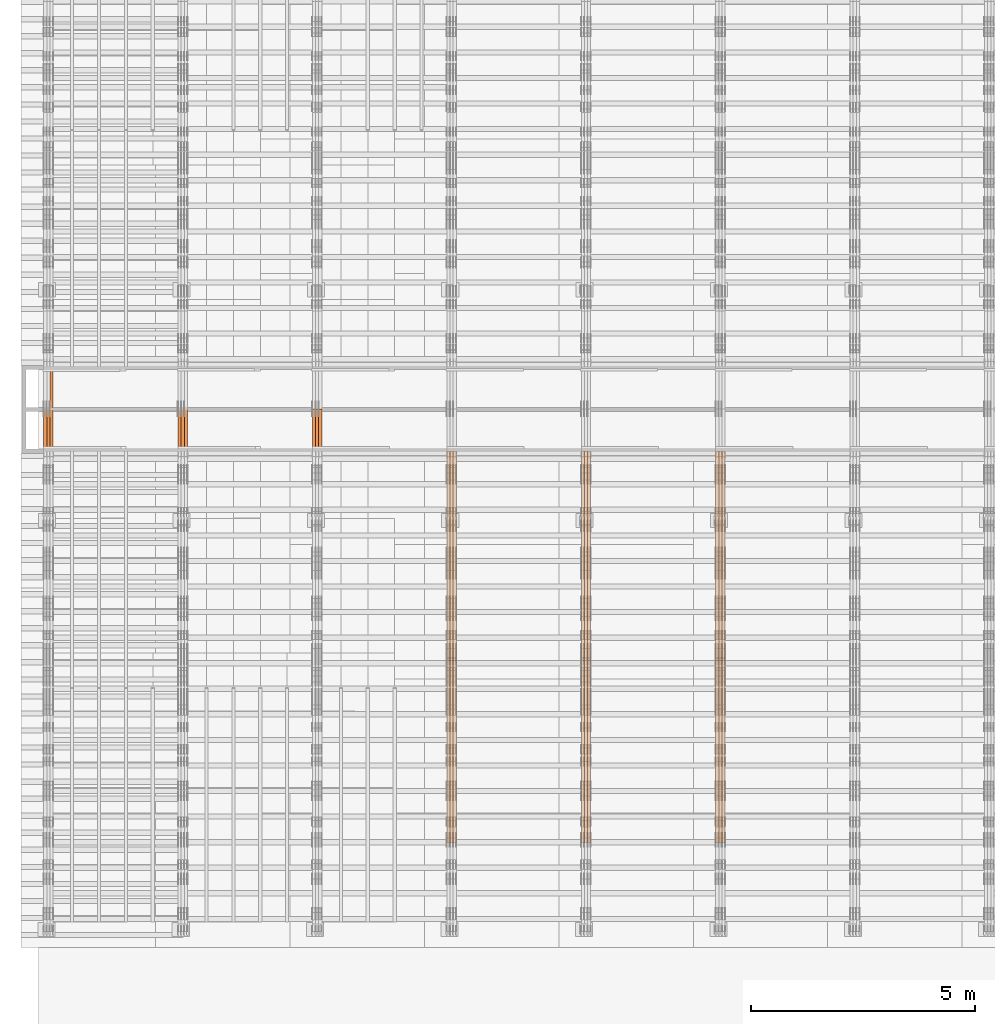
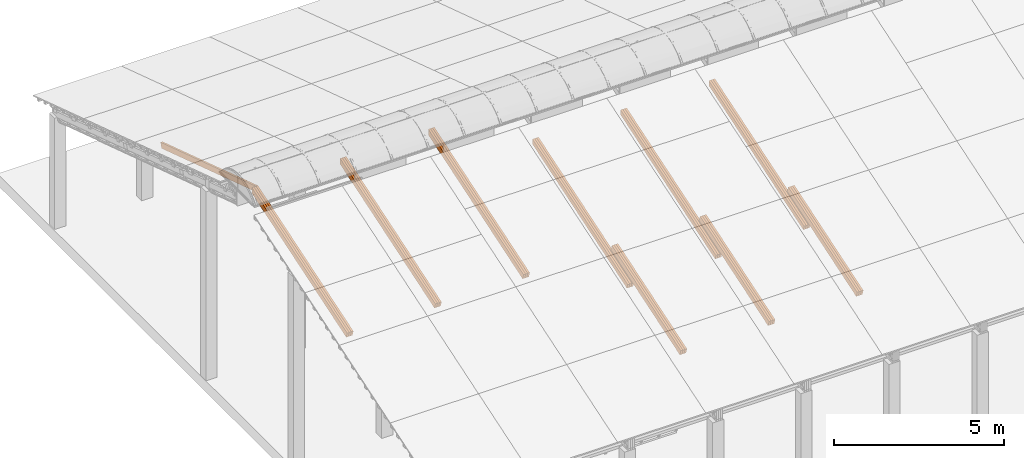
# One storey, part 13 of 385: 28 proxies.
"""IFC2X3 building model written with IfcOpenShell, lengths in millimetres."""

import ifcopenshell
import ifcopenshell.guid

model = None  # the IFC model being written
_history = None  # IfcOwnerHistory: only IFC2X3 demands one
_inside = {}  # id of a spatial element -> (the spatial element, [elements in it])
_under = {}  # id of a project, library or spatial element -> (it, [spatial elements below it])
_declared = {}  # id of a project -> (the project, [libraries it declares])
_typed = {}  # id of a type object -> (the type object, [elements of that type])
_made_of = {}  # id of a material, layer set ... -> (it, [elements and type objects made of it])


def new_model(schema):
    """Start an empty IFC model of exactly this schema.

    Asked for "IFC4X3", IfcOpenShell would pick the latest addendum, in which some entities
    have other attributes; the version numbers below select the first issue.
    IFC2X3 requires an IfcOwnerHistory on every rooted entity: one is made here for all.
    """
    global model, _history
    if schema == "IFC4X3":
        model = ifcopenshell.file(schema_version=(4, 3, 0, 0))
    else:
        model = ifcopenshell.file(schema=schema)
    _inside.clear()
    _under.clear()
    _declared.clear()
    _typed.clear()
    _made_of.clear()
    _history = None
    if model.schema == "IFC2X3":
        org = make("IfcOrganization", Name="unknown")
        user = make(
            "IfcPersonAndOrganization",
            ThePerson=make("IfcPerson", FamilyName="unknown"),
            TheOrganization=org,
        )
        app = make(
            "IfcApplication",
            ApplicationDeveloper=org,
            Version="unknown",
            ApplicationFullName="unknown",
            ApplicationIdentifier="unknown",
        )
        _history = make(
            "IfcOwnerHistory",
            OwningUser=user,
            OwningApplication=app,
            ChangeAction="ADDED",
            CreationDate=0,
        )
    return model


def make(cls, **values):
    """One entity of the class cls with the attributes given. An attribute that is None is left unset."""
    return model.create_entity(
        cls, **{name: value for name, value in values.items() if value is not None}
    )


def entity(cls, *values):
    """Any entity or typed value of the class cls, its attributes in the order of the schema. None: left unset."""
    e = model.create_entity(cls)
    for i, value in enumerate(values):
        if value is not None:
            e[i] = value
    return e


def rooted(cls, **values):
    """An entity with a GlobalId (a new one), such as an element, a storey or a relation."""
    return make(cls, GlobalId=ifcopenshell.guid.new(), OwnerHistory=_history, **values)


def si_unit(unit_type, name, prefix=None):
    """IfcSIUnit, for example si_unit("LENGTHUNIT", "METRE", prefix="MILLI")."""
    return make("IfcSIUnit", UnitType=unit_type, Prefix=prefix, Name=name)


def converted_unit(unit_type, name, factor, base, dimensions=None, offset=None):
    """IfcConversionBasedUnit, such as the inch: factor (a typed value) times the base unit."""
    return make(
        "IfcConversionBasedUnit"
        if offset is None
        else "IfcConversionBasedUnitWithOffset",
        ConversionOffset=offset,
        Dimensions=None
        if dimensions is None
        else entity("IfcDimensionalExponents", *dimensions),
        UnitType=unit_type,
        Name=name,
        ConversionFactor=make(
            "IfcMeasureWithUnit", ValueComponent=factor, UnitComponent=base
        ),
    )


def derived_unit(unit_type, elements):
    """IfcDerivedUnit: a product of units, each with its exponent."""
    return make(
        "IfcDerivedUnit",
        Elements=[
            make("IfcDerivedUnitElement", Unit=unit, Exponent=power)
            for unit, power in elements
        ],
        UnitType=unit_type,
    )


def assignment(units):
    """IfcUnitAssignment: the units of a project."""
    return None if units is None else make("IfcUnitAssignment", Units=units)


def point(xyz):
    """IfcCartesianPoint."""
    return None if xyz is None else make("IfcCartesianPoint", Coordinates=xyz)


def direction(xyz):
    """IfcDirection."""
    return None if xyz is None else make("IfcDirection", DirectionRatios=xyz)


def frame(location, z_axis=None, x_axis=None):
    """IfcAxis2Placement3D, a coordinate frame: its origin and axes. An axis left out is left unset."""
    return make(
        "IfcAxis2Placement3D",
        Location=point(location),
        Axis=direction(z_axis),
        RefDirection=direction(x_axis),
    )


def origin():
    """The frame at (0, 0, 0) with its axes left unset."""
    return frame((0.0, 0.0, 0.0))


def place(relative_to, where):
    """IfcLocalPlacement: puts the frame where relative to a parent placement (None: the world)."""
    return make(
        "IfcLocalPlacement", PlacementRelTo=relative_to, RelativePlacement=where
    )


def context(
    kind, dimensions, precision=None, world=None, true_north=None, identifier=None
):
    """IfcGeometricRepresentationContext, for example the 3D "Model" context."""
    return make(
        "IfcGeometricRepresentationContext",
        ContextIdentifier=identifier,
        ContextType=kind,
        CoordinateSpaceDimension=dimensions,
        Precision=precision,
        WorldCoordinateSystem=world,
        TrueNorth=true_north,
    )


def subcontext(parent, identifier, kind, view, scale=None):
    """IfcGeometricRepresentationSubContext, for example "Body" below "Model"."""
    return make(
        "IfcGeometricRepresentationSubContext",
        ContextIdentifier=identifier,
        ContextType=kind,
        ParentContext=parent,
        TargetScale=scale,
        TargetView=view,
    )


def project(units=None, contexts=None):
    """IfcProject with its units and contexts."""
    return rooted(
        "IfcProject",
        Name="project",
        RepresentationContexts=contexts,
        UnitsInContext=assignment(units),
    )


def spatial(cls, under=None, at=None, **own):
    """A site, building, storey or space (cls), placed at a placement, below another one or the project."""
    s = rooted(cls, ObjectPlacement=at, **own)
    if under is not None:
        _under.setdefault(under.id(), (under, []))[1].append(s)
    return s


def polyline(points):
    """IfcPolyline through the points."""
    return make("IfcPolyline", Points=[point(p) for p in points])


def outline(outer, holes=None, kind="AREA"):
    """IfcArbitraryClosedProfileDef: a profile drawn as a closed curve; with holes, ...WithVoids."""
    if holes is None:
        return make("IfcArbitraryClosedProfileDef", ProfileType=kind, OuterCurve=outer)
    return make(
        "IfcArbitraryProfileDefWithVoids",
        ProfileType=kind,
        OuterCurve=outer,
        InnerCurves=holes,
    )


def extrude(swept, where, along, depth):
    """IfcExtrudedAreaSolid: the profile swept, set in the frame where, extruded along a direction by depth."""
    return make(
        "IfcExtrudedAreaSolid",
        SweptArea=swept,
        Position=where,
        ExtrudedDirection=direction(along),
        Depth=depth,
    )


def shape(context_of_items, identifier, shape_type, items):
    """IfcShapeRepresentation: the items that make up one representation, for example the "Body"."""
    return make(
        "IfcShapeRepresentation",
        ContextOfItems=context_of_items,
        RepresentationIdentifier=identifier,
        RepresentationType=shape_type,
        Items=items,
    )


def source(mapping_origin, context_of_items, identifier, shape_type, items):
    """IfcRepresentationMap: a shape defined once, which mapped items show again and again."""
    return make(
        "IfcRepresentationMap",
        MappingOrigin=mapping_origin,
        MappedRepresentation=shape(context_of_items, identifier, shape_type, items),
    )


def transform(
    local_origin,
    x_axis=None,
    y_axis=None,
    z_axis=None,
    scale=None,
    scale2=None,
    scale3=None,
    uniform=True,
):
    """IfcCartesianTransformationOperator3D, or its non-uniform kind. x_axis, y_axis, z_axis: its Axis1, 2, 3."""
    if uniform:
        return make(
            "IfcCartesianTransformationOperator3D",
            Axis1=direction(x_axis),
            Axis2=direction(y_axis),
            LocalOrigin=point(local_origin),
            Scale=scale,
            Axis3=direction(z_axis),
        )
    return make(
        "IfcCartesianTransformationOperator3DnonUniform",
        Axis1=direction(x_axis),
        Axis2=direction(y_axis),
        LocalOrigin=point(local_origin),
        Scale=scale,
        Axis3=direction(z_axis),
        Scale2=scale2,
        Scale3=scale3,
    )


def mapped(mapping_source, mapping_target):
    """IfcMappedItem: shows the shape of a source again, moved by a transform."""
    return make(
        "IfcMappedItem", MappingSource=mapping_source, MappingTarget=mapping_target
    )


def material(Name=None, Category=None):
    """IfcMaterial."""
    return make("IfcMaterial", Name=Name, Category=Category)


def made_of(thing, what):
    """Note that an element or type object is made of a material, layer set ...; save() writes the relation."""
    if what is not None:
        _made_of.setdefault(what.id(), (what, []))[1].append(thing)
    return thing


def type_object(cls, material=None, **own):
    """A type object (cls), such as IfcWallType, which elements share."""
    return made_of(rooted(cls, **own), material)


def type_shapes(of_type, sources):
    """Give a type object the sources (RepresentationMaps) that its elements show as mapped items."""
    of_type.RepresentationMaps = sources


def element(
    cls,
    number,
    at=None,
    inside=None,
    cuts=None,
    type_object=None,
    material=None,
    context=None,
    identifier="Body",
    shape_type=None,
    held_by="IfcProductDefinitionShape",
    body=None,
    shapes=None,
    **own,
):
    """One element of the class cls, such as IfcWall. Its Tag is "e" and its number.

    at: its placement. inside: the storey or other place that contains it. cuts: it is an
    opening in that element (IfcRelVoidsElement). A single representation is given by context,
    identifier, shape_type and body (its items); several are given by shapes. held_by: the class
    of the entity that holds the representations. save() writes the other relations.
    """
    e = rooted(cls, Tag="e%d" % number, ObjectPlacement=at, **own)
    if body is not None:
        shapes = [shape(context, identifier, shape_type, body)]
    if shapes is not None:
        e.Representation = make(held_by, Representations=shapes)
    if inside is not None:
        _inside.setdefault(inside.id(), (inside, []))[1].append(e)
    if cuts is not None:
        rooted(
            "IfcRelVoidsElement", RelatingBuildingElement=cuts, RelatedOpeningElement=e
        )
    if type_object is not None:
        _typed.setdefault(type_object.id(), (type_object, []))[1].append(e)
    return made_of(e, material)


def aggregate(whole, parts):
    """IfcRelAggregates: a whole, such as a stair, and the parts it consists of."""
    return rooted("IfcRelAggregates", RelatingObject=whole, RelatedObjects=parts)


def save(model, path):
    """Write the relations noted so far, then the file.

    IfcRelAggregates (storeys below a building ...), IfcRelContainedInSpatialStructure (elements
    in a storey), IfcRelDefinesByType, IfcRelAssociatesMaterial and IfcRelDeclares: one each for
    every whole, place, type object, material and project.
    """
    for whole, parts in _under.values():
        aggregate(whole, parts)
    for where, things in _inside.values():
        rooted(
            "IfcRelContainedInSpatialStructure",
            RelatedElements=things,
            RelatingStructure=where,
        )
    for kind, things in _typed.values():
        rooted("IfcRelDefinesByType", RelatedObjects=things, RelatingType=kind)
    for what, things in _made_of.values():
        rooted("IfcRelAssociatesMaterial", RelatedObjects=things, RelatingMaterial=what)
    for by, libraries in _declared.values():
        rooted("IfcRelDeclares", RelatingContext=by, RelatedDefinitions=libraries)
    model.write(path)


model = new_model("IFC2X3")

# Units and contexts
model_context = context("Model", 3, precision=0.01, world=origin(), true_north=direction((6.12303176911189e-17, 1.0)))
body_context = subcontext(model_context, "Body", "Model", "MODEL_VIEW")
ifc_project = project(units=[si_unit("LENGTHUNIT", "METRE", prefix="MILLI"), si_unit("AREAUNIT", "SQUARE_METRE"), si_unit("VOLUMEUNIT", "CUBIC_METRE"), converted_unit("PLANEANGLEUNIT", "DEGREE", entity("IfcRatioMeasure", 0.0174532925199433), si_unit("PLANEANGLEUNIT", "RADIAN"), dimensions=[0, 0, 0, 0, 0, 0, 0]), si_unit("MASSUNIT", "GRAM", prefix="KILO"), derived_unit("MASSDENSITYUNIT", [(si_unit("MASSUNIT", "GRAM", prefix="KILO"), 1), (si_unit("LENGTHUNIT", "METRE"), -3)]), si_unit("TIMEUNIT", "SECOND"), si_unit("FREQUENCYUNIT", "HERTZ"), si_unit("THERMODYNAMICTEMPERATUREUNIT", "DEGREE_CELSIUS"), derived_unit("THERMALTRANSMITTANCEUNIT", [(si_unit("MASSUNIT", "GRAM", prefix="KILO"), 1), (si_unit("THERMODYNAMICTEMPERATUREUNIT", "KELVIN"), -1), (si_unit("TIMEUNIT", "SECOND"), -3)]), derived_unit("VOLUMETRICFLOWRATEUNIT", [(si_unit("LENGTHUNIT", "METRE"), 3), (si_unit("TIMEUNIT", "SECOND"), -1)]), si_unit("ELECTRICCURRENTUNIT", "AMPERE"), si_unit("ELECTRICVOLTAGEUNIT", "VOLT"), si_unit("POWERUNIT", "WATT"), si_unit("FORCEUNIT", "NEWTON", prefix="KILO"), si_unit("ILLUMINANCEUNIT", "LUX"), si_unit("LUMINOUSFLUXUNIT", "LUMEN"), si_unit("LUMINOUSINTENSITYUNIT", "CANDELA"), derived_unit("USERDEFINED", [(si_unit("MASSUNIT", "GRAM", prefix="KILO"), -1), (si_unit("LENGTHUNIT", "METRE"), -2), (si_unit("TIMEUNIT", "SECOND"), 3), (si_unit("LUMINOUSFLUXUNIT", "LUMEN"), 1)]), derived_unit("LINEARVELOCITYUNIT", [(si_unit("LENGTHUNIT", "METRE"), 1), (si_unit("TIMEUNIT", "SECOND"), -1)]), si_unit("PRESSUREUNIT", "PASCAL"), derived_unit("USERDEFINED", [(si_unit("LENGTHUNIT", "METRE"), -2), (si_unit("MASSUNIT", "GRAM", prefix="KILO"), 1), (si_unit("TIMEUNIT", "SECOND"), -2)])], contexts=[model_context])

# Site, building, storey
site_placement = place(None, origin())
site = spatial("IfcSite", under=ifc_project, at=site_placement, CompositionType="ELEMENT")
building_placement = place(site_placement, origin())
building = spatial("IfcBuilding", under=site, at=building_placement, CompositionType="ELEMENT")
storey_placement = place(building_placement, origin())
storey = spatial("IfcBuildingStorey", under=building, at=storey_placement, Name="Default", CompositionType="ELEMENT", Elevation=0.0)

# Proxies
ifc_material_1 = material(Name="IfcSurfaceStyle #179836")
building_element_proxy_type_1 = type_object("IfcBuildingElementProxyType", Name="T1-T2 179834", PredefinedType="NOTDEFINED", material=ifc_material_1)
shared_shape_1 = source(origin(), body_context, "Body", "SweptSolid", [
    extrude(outline(polyline([(-2137.04475371072, -97.5001541485635), (2137.04431231695, -97.5001541485635), (2137.0438249446, 97.5001541485636), (-2137.04338355082, 97.5001541485635), (-2137.04475371072, -97.5001541485635)])), frame((2137.04431231695, 97.5003268035489, 0.0), z_axis=(0.0, 0.0, 1.0), x_axis=(-1.0, 0.0, 0.0)), (0.0, 0.0, 1.0), 69.9999999999997),
])
type_shapes(building_element_proxy_type_1, [shared_shape_1])
proxy_1_placement = place(building_placement, frame((15385.0, 9160.11575124697, 2416.00267194857), z_axis=(-1.0, 0.0, 0.0), x_axis=(0.0, -0.951056516295154, -0.309016994374948)))
element("IfcBuildingElementProxy", 1, at=proxy_1_placement, inside=storey, type_object=building_element_proxy_type_1, material=ifc_material_1, Name="T1-T2", context=body_context, shape_type="MappedRepresentation", body=[
    mapped(shared_shape_1, transform((0.0, 0.0, 0.0), scale=1.0)),
])
ifc_material_2 = material(Name="IfcSurfaceStyle #179779")
building_element_proxy_type_2 = type_object("IfcBuildingElementProxyType", Name="T1-T2 179777", PredefinedType="NOTDEFINED", material=ifc_material_2)
shared_shape_2 = source(origin(), body_context, "Body", "SweptSolid", [
    extrude(outline(polyline([(-2137.04475371072, -97.5001541485635), (2137.04431231695, -97.5001541485635), (2137.0438249446, 97.5001541485636), (-2137.04338355082, 97.5001541485635), (-2137.04475371072, -97.5001541485635)])), frame((2137.04431231695, 97.5003268035489, 0.0), z_axis=(0.0, 0.0, 1.0), x_axis=(-1.0, 0.0, 0.0)), (0.0, 0.0, 1.0), 69.9999999999997),
])
type_shapes(building_element_proxy_type_2, [shared_shape_2])
proxy_2_placement = place(building_placement, frame((15315.0, 9160.11575124697, 2416.00267194857), z_axis=(-1.0, 0.0, 0.0), x_axis=(0.0, -0.951056516295154, -0.309016994374948)))
element("IfcBuildingElementProxy", 2, at=proxy_2_placement, inside=storey, type_object=building_element_proxy_type_2, material=ifc_material_2, Name="T1-T2", context=body_context, shape_type="MappedRepresentation", body=[
    mapped(shared_shape_2, transform((0.0, 0.0, 0.0), scale=1.0)),
])
ifc_material_3 = material(Name="IfcSurfaceStyle #179722")
building_element_proxy_type_3 = type_object("IfcBuildingElementProxyType", Name="T1-T2 179720", PredefinedType="NOTDEFINED", material=ifc_material_3)
shared_shape_3 = source(origin(), body_context, "Body", "SweptSolid", [
    extrude(outline(polyline([(-2137.04475371072, -97.5001541485635), (2137.04431231695, -97.5001541485635), (2137.0438249446, 97.5001541485636), (-2137.04338355082, 97.5001541485635), (-2137.04475371072, -97.5001541485635)])), frame((2137.04431231695, 97.5003268035489, 0.0), z_axis=(0.0, 0.0, 1.0), x_axis=(-1.0, 0.0, 0.0)), (0.0, 0.0, 1.0), 69.9999999999997),
])
type_shapes(building_element_proxy_type_3, [shared_shape_3])
proxy_3_placement = place(building_placement, frame((15245.0, 9160.11575124697, 2416.00267194857), z_axis=(-1.0, 0.0, 0.0), x_axis=(0.0, -0.951056516295154, -0.309016994374948)))
element("IfcBuildingElementProxy", 3, at=proxy_3_placement, inside=storey, type_object=building_element_proxy_type_3, material=ifc_material_3, Name="T1-T2", context=body_context, shape_type="MappedRepresentation", body=[
    mapped(shared_shape_3, transform((0.0, 0.0, 0.0), scale=1.0)),
])
ifc_material_4 = material(Name="IfcSurfaceStyle #179494")
building_element_proxy_type_4 = type_object("IfcBuildingElementProxyType", Name="T1-B4 179492", PredefinedType="NOTDEFINED", material=ifc_material_4)
shared_shape_4 = source(origin(), body_context, "Body", "SweptSolid", [
    extrude(outline(polyline([(-2912.13310129284, -85.0000958683222), (2939.75111293783, -85.0000958683222), (2939.75142473078, 85.0000958683222), (-2967.36943637577, 85.0000958683222), (-2912.13310129284, -85.0000958683222)])), frame((2939.75142473078, 85.0000958683222, 0.0), z_axis=(0.0, 0.0, 1.0), x_axis=(-1.0, 0.0, 0.0)), (0.0, 0.0, 1.0), 69.9999999999996),
])
type_shapes(building_element_proxy_type_4, [shared_shape_4])
proxy_4_placement = place(building_placement, frame((15385.0, 8161.994140625, 1765.00476074219), z_axis=(-1.0, 0.0, 0.0), x_axis=(0.0, 0.951056516295124, 0.309016994375039)))
element("IfcBuildingElementProxy", 4, at=proxy_4_placement, inside=storey, type_object=building_element_proxy_type_4, material=ifc_material_4, Name="T1-B4", context=body_context, shape_type="MappedRepresentation", body=[
    mapped(shared_shape_4, transform((0.0, 0.0, 0.0), scale=1.0)),
])
ifc_material_5 = material(Name="IfcSurfaceStyle #179437")
building_element_proxy_type_5 = type_object("IfcBuildingElementProxyType", Name="T1-B4 179435", PredefinedType="NOTDEFINED", material=ifc_material_5)
shared_shape_5 = source(origin(), body_context, "Body", "SweptSolid", [
    extrude(outline(polyline([(-2912.13310129284, -85.0000958683222), (2939.75111293783, -85.0000958683222), (2939.75142473078, 85.0000958683222), (-2967.36943637577, 85.0000958683222), (-2912.13310129284, -85.0000958683222)])), frame((2939.75142473078, 85.0000958683222, 0.0), z_axis=(0.0, 0.0, 1.0), x_axis=(-1.0, 0.0, 0.0)), (0.0, 0.0, 1.0), 69.9999999999996),
])
type_shapes(building_element_proxy_type_5, [shared_shape_5])
proxy_5_placement = place(building_placement, frame((15315.0, 8161.994140625, 1765.00476074219), z_axis=(-1.0, 0.0, 0.0), x_axis=(0.0, 0.951056516295124, 0.309016994375039)))
element("IfcBuildingElementProxy", 5, at=proxy_5_placement, inside=storey, type_object=building_element_proxy_type_5, material=ifc_material_5, Name="T1-B4", context=body_context, shape_type="MappedRepresentation", body=[
    mapped(shared_shape_5, transform((0.0, 0.0, 0.0), scale=1.0)),
])
ifc_material_6 = material(Name="IfcSurfaceStyle #179380")
building_element_proxy_type_6 = type_object("IfcBuildingElementProxyType", Name="T1-B4 179378", PredefinedType="NOTDEFINED", material=ifc_material_6)
shared_shape_6 = source(origin(), body_context, "Body", "SweptSolid", [
    extrude(outline(polyline([(-2912.13310129284, -85.0000958683222), (2939.75111293783, -85.0000958683222), (2939.75142473078, 85.0000958683222), (-2967.36943637577, 85.0000958683222), (-2912.13310129284, -85.0000958683222)])), frame((2939.75142473078, 85.0000958683222, 0.0), z_axis=(0.0, 0.0, 1.0), x_axis=(-1.0, 0.0, 0.0)), (0.0, 0.0, 1.0), 69.9999999999996),
])
type_shapes(building_element_proxy_type_6, [shared_shape_6])
proxy_6_placement = place(building_placement, frame((15245.0, 8161.994140625, 1765.00476074219), z_axis=(-1.0, 0.0, 0.0), x_axis=(0.0, 0.951056516295124, 0.309016994375039)))
element("IfcBuildingElementProxy", 6, at=proxy_6_placement, inside=storey, type_object=building_element_proxy_type_6, material=ifc_material_6, Name="T1-B4", context=body_context, shape_type="MappedRepresentation", body=[
    mapped(shared_shape_6, transform((0.0, 0.0, 0.0), scale=1.0)),
])
ifc_material_7 = material(Name="IfcSurfaceStyle #145404")
building_element_proxy_type_7 = type_object("IfcBuildingElementProxyType", Name="T1-T2 145402", PredefinedType="NOTDEFINED", material=ifc_material_7)
shared_shape_7 = source(origin(), body_context, "Body", "SweptSolid", [
    extrude(outline(polyline([(-2137.04475371072, -97.5001541485635), (2137.04431231695, -97.5001541485635), (2137.0438249446, 97.5001541485636), (-2137.04338355082, 97.5001541485635), (-2137.04475371072, -97.5001541485635)])), frame((2137.04431231695, 97.5003268035489, 0.0), z_axis=(0.0, 0.0, 1.0), x_axis=(-1.0, 0.0, 0.0)), (0.0, 0.0, 1.0), 69.9999999999997),
])
type_shapes(building_element_proxy_type_7, [shared_shape_7])
proxy_7_placement = place(building_placement, frame((12385.0, 9160.11575124697, 2416.00267194857), z_axis=(-1.0, 0.0, 0.0), x_axis=(0.0, -0.951056516295154, -0.309016994374948)))
element("IfcBuildingElementProxy", 7, at=proxy_7_placement, inside=storey, type_object=building_element_proxy_type_7, material=ifc_material_7, Name="T1-T2", context=body_context, shape_type="MappedRepresentation", body=[
    mapped(shared_shape_7, transform((0.0, 0.0, 0.0), scale=1.0)),
])
ifc_material_8 = material(Name="IfcSurfaceStyle #145347")
building_element_proxy_type_8 = type_object("IfcBuildingElementProxyType", Name="T1-T2 145345", PredefinedType="NOTDEFINED", material=ifc_material_8)
shared_shape_8 = source(origin(), body_context, "Body", "SweptSolid", [
    extrude(outline(polyline([(-2137.04475371072, -97.5001541485635), (2137.04431231695, -97.5001541485635), (2137.0438249446, 97.5001541485636), (-2137.04338355082, 97.5001541485635), (-2137.04475371072, -97.5001541485635)])), frame((2137.04431231695, 97.5003268035489, 0.0), z_axis=(0.0, 0.0, 1.0), x_axis=(-1.0, 0.0, 0.0)), (0.0, 0.0, 1.0), 69.9999999999997),
])
type_shapes(building_element_proxy_type_8, [shared_shape_8])
proxy_8_placement = place(building_placement, frame((12315.0, 9160.11575124697, 2416.00267194857), z_axis=(-1.0, 0.0, 0.0), x_axis=(0.0, -0.951056516295154, -0.309016994374948)))
element("IfcBuildingElementProxy", 8, at=proxy_8_placement, inside=storey, type_object=building_element_proxy_type_8, material=ifc_material_8, Name="T1-T2", context=body_context, shape_type="MappedRepresentation", body=[
    mapped(shared_shape_8, transform((0.0, 0.0, 0.0), scale=1.0)),
])
ifc_material_9 = material(Name="IfcSurfaceStyle #145290")
building_element_proxy_type_9 = type_object("IfcBuildingElementProxyType", Name="T1-T2 145288", PredefinedType="NOTDEFINED", material=ifc_material_9)
shared_shape_9 = source(origin(), body_context, "Body", "SweptSolid", [
    extrude(outline(polyline([(-2137.04475371072, -97.5001541485635), (2137.04431231695, -97.5001541485635), (2137.0438249446, 97.5001541485636), (-2137.04338355082, 97.5001541485635), (-2137.04475371072, -97.5001541485635)])), frame((2137.04431231695, 97.5003268035489, 0.0), z_axis=(0.0, 0.0, 1.0), x_axis=(-1.0, 0.0, 0.0)), (0.0, 0.0, 1.0), 69.9999999999997),
])
type_shapes(building_element_proxy_type_9, [shared_shape_9])
proxy_9_placement = place(building_placement, frame((12245.0, 9160.11575124697, 2416.00267194857), z_axis=(-1.0, 0.0, 0.0), x_axis=(0.0, -0.951056516295154, -0.309016994374948)))
element("IfcBuildingElementProxy", 9, at=proxy_9_placement, inside=storey, type_object=building_element_proxy_type_9, material=ifc_material_9, Name="T1-T2", context=body_context, shape_type="MappedRepresentation", body=[
    mapped(shared_shape_9, transform((0.0, 0.0, 0.0), scale=1.0)),
])
ifc_material_10 = material(Name="IfcSurfaceStyle #145062")
building_element_proxy_type_10 = type_object("IfcBuildingElementProxyType", Name="T1-B4 145060", PredefinedType="NOTDEFINED", material=ifc_material_10)
shared_shape_10 = source(origin(), body_context, "Body", "SweptSolid", [
    extrude(outline(polyline([(-2912.13310129284, -85.0000958683222), (2939.75111293783, -85.0000958683222), (2939.75142473078, 85.0000958683222), (-2967.36943637577, 85.0000958683222), (-2912.13310129284, -85.0000958683222)])), frame((2939.75142473078, 85.0000958683222, 0.0), z_axis=(0.0, 0.0, 1.0), x_axis=(-1.0, 0.0, 0.0)), (0.0, 0.0, 1.0), 69.9999999999996),
])
type_shapes(building_element_proxy_type_10, [shared_shape_10])
proxy_10_placement = place(building_placement, frame((12385.0, 8161.994140625, 1765.00476074219), z_axis=(-1.0, 0.0, 0.0), x_axis=(0.0, 0.951056516295124, 0.309016994375039)))
element("IfcBuildingElementProxy", 10, at=proxy_10_placement, inside=storey, type_object=building_element_proxy_type_10, material=ifc_material_10, Name="T1-B4", context=body_context, shape_type="MappedRepresentation", body=[
    mapped(shared_shape_10, transform((0.0, 0.0, 0.0), scale=1.0)),
])
ifc_material_11 = material(Name="IfcSurfaceStyle #145005")
building_element_proxy_type_11 = type_object("IfcBuildingElementProxyType", Name="T1-B4 145003", PredefinedType="NOTDEFINED", material=ifc_material_11)
shared_shape_11 = source(origin(), body_context, "Body", "SweptSolid", [
    extrude(outline(polyline([(-2912.13310129284, -85.0000958683222), (2939.75111293783, -85.0000958683222), (2939.75142473078, 85.0000958683222), (-2967.36943637577, 85.0000958683222), (-2912.13310129284, -85.0000958683222)])), frame((2939.75142473078, 85.0000958683222, 0.0), z_axis=(0.0, 0.0, 1.0), x_axis=(-1.0, 0.0, 0.0)), (0.0, 0.0, 1.0), 69.9999999999996),
])
type_shapes(building_element_proxy_type_11, [shared_shape_11])
proxy_11_placement = place(building_placement, frame((12315.0, 8161.994140625, 1765.00476074219), z_axis=(-1.0, 0.0, 0.0), x_axis=(0.0, 0.951056516295124, 0.309016994375039)))
element("IfcBuildingElementProxy", 11, at=proxy_11_placement, inside=storey, type_object=building_element_proxy_type_11, material=ifc_material_11, Name="T1-B4", context=body_context, shape_type="MappedRepresentation", body=[
    mapped(shared_shape_11, transform((0.0, 0.0, 0.0), scale=1.0)),
])
ifc_material_12 = material(Name="IfcSurfaceStyle #144948")
building_element_proxy_type_12 = type_object("IfcBuildingElementProxyType", Name="T1-B4 144946", PredefinedType="NOTDEFINED", material=ifc_material_12)
shared_shape_12 = source(origin(), body_context, "Body", "SweptSolid", [
    extrude(outline(polyline([(-2912.13310129284, -85.0000958683222), (2939.75111293783, -85.0000958683222), (2939.75142473078, 85.0000958683222), (-2967.36943637577, 85.0000958683222), (-2912.13310129284, -85.0000958683222)])), frame((2939.75142473078, 85.0000958683222, 0.0), z_axis=(0.0, 0.0, 1.0), x_axis=(-1.0, 0.0, 0.0)), (0.0, 0.0, 1.0), 69.9999999999996),
])
type_shapes(building_element_proxy_type_12, [shared_shape_12])
proxy_12_placement = place(building_placement, frame((12245.0, 8161.994140625, 1765.00476074219), z_axis=(-1.0, 0.0, 0.0), x_axis=(0.0, 0.951056516295124, 0.309016994375039)))
element("IfcBuildingElementProxy", 12, at=proxy_12_placement, inside=storey, type_object=building_element_proxy_type_12, material=ifc_material_12, Name="T1-B4", context=body_context, shape_type="MappedRepresentation", body=[
    mapped(shared_shape_12, transform((0.0, 0.0, 0.0), scale=1.0)),
])
ifc_material_13 = material(Name="IfcSurfaceStyle #110972")
building_element_proxy_type_13 = type_object("IfcBuildingElementProxyType", Name="T1-T2 110970", PredefinedType="NOTDEFINED", material=ifc_material_13)
shared_shape_13 = source(origin(), body_context, "Body", "SweptSolid", [
    extrude(outline(polyline([(-2137.04475371072, -97.5001541485635), (2137.04431231695, -97.5001541485635), (2137.0438249446, 97.5001541485636), (-2137.04338355082, 97.5001541485635), (-2137.04475371072, -97.5001541485635)])), frame((2137.04431231695, 97.5003268035489, 0.0), z_axis=(0.0, 0.0, 1.0), x_axis=(-1.0, 0.0, 0.0)), (0.0, 0.0, 1.0), 69.9999999999997),
])
type_shapes(building_element_proxy_type_13, [shared_shape_13])
proxy_13_placement = place(building_placement, frame((9385.0, 9160.11575124698, 2416.00267194857), z_axis=(-1.0, 0.0, 0.0), x_axis=(0.0, -0.951056516295154, -0.309016994374948)))
element("IfcBuildingElementProxy", 13, at=proxy_13_placement, inside=storey, type_object=building_element_proxy_type_13, material=ifc_material_13, Name="T1-T2", context=body_context, shape_type="MappedRepresentation", body=[
    mapped(shared_shape_13, transform((0.0, 0.0, 0.0), scale=1.0)),
])
ifc_material_14 = material(Name="IfcSurfaceStyle #110915")
building_element_proxy_type_14 = type_object("IfcBuildingElementProxyType", Name="T1-T2 110913", PredefinedType="NOTDEFINED", material=ifc_material_14)
shared_shape_14 = source(origin(), body_context, "Body", "SweptSolid", [
    extrude(outline(polyline([(-2137.04475371072, -97.5001541485635), (2137.04431231695, -97.5001541485635), (2137.0438249446, 97.5001541485636), (-2137.04338355082, 97.5001541485635), (-2137.04475371072, -97.5001541485635)])), frame((2137.04431231695, 97.5003268035489, 0.0), z_axis=(0.0, 0.0, 1.0), x_axis=(-1.0, 0.0, 0.0)), (0.0, 0.0, 1.0), 69.9999999999997),
])
type_shapes(building_element_proxy_type_14, [shared_shape_14])
proxy_14_placement = place(building_placement, frame((9315.0, 9160.11575124698, 2416.00267194857), z_axis=(-1.0, 0.0, 0.0), x_axis=(0.0, -0.951056516295154, -0.309016994374948)))
element("IfcBuildingElementProxy", 14, at=proxy_14_placement, inside=storey, type_object=building_element_proxy_type_14, material=ifc_material_14, Name="T1-T2", context=body_context, shape_type="MappedRepresentation", body=[
    mapped(shared_shape_14, transform((0.0, 0.0, 0.0), scale=1.0)),
])
ifc_material_15 = material(Name="IfcSurfaceStyle #110858")
building_element_proxy_type_15 = type_object("IfcBuildingElementProxyType", Name="T1-T2 110856", PredefinedType="NOTDEFINED", material=ifc_material_15)
shared_shape_15 = source(origin(), body_context, "Body", "SweptSolid", [
    extrude(outline(polyline([(-2137.04475371072, -97.5001541485635), (2137.04431231695, -97.5001541485635), (2137.0438249446, 97.5001541485636), (-2137.04338355082, 97.5001541485635), (-2137.04475371072, -97.5001541485635)])), frame((2137.04431231695, 97.5003268035489, 0.0), z_axis=(0.0, 0.0, 1.0), x_axis=(-1.0, 0.0, 0.0)), (0.0, 0.0, 1.0), 69.9999999999997),
])
type_shapes(building_element_proxy_type_15, [shared_shape_15])
proxy_15_placement = place(building_placement, frame((9245.0, 9160.11575124698, 2416.00267194857), z_axis=(-1.0, 0.0, 0.0), x_axis=(0.0, -0.951056516295154, -0.309016994374948)))
element("IfcBuildingElementProxy", 15, at=proxy_15_placement, inside=storey, type_object=building_element_proxy_type_15, material=ifc_material_15, Name="T1-T2", context=body_context, shape_type="MappedRepresentation", body=[
    mapped(shared_shape_15, transform((0.0, 0.0, 0.0), scale=1.0)),
])
ifc_material_16 = material(Name="IfcSurfaceStyle #110630")
building_element_proxy_type_16 = type_object("IfcBuildingElementProxyType", Name="T1-B4 110628", PredefinedType="NOTDEFINED", material=ifc_material_16)
shared_shape_16 = source(origin(), body_context, "Body", "SweptSolid", [
    extrude(outline(polyline([(-2912.13310129284, -85.0000958683222), (2939.75111293783, -85.0000958683222), (2939.75142473078, 85.0000958683222), (-2967.36943637577, 85.0000958683222), (-2912.13310129284, -85.0000958683222)])), frame((2939.75142473078, 85.0000958683222, 0.0), z_axis=(0.0, 0.0, 1.0), x_axis=(-1.0, 0.0, 0.0)), (0.0, 0.0, 1.0), 69.9999999999996),
])
type_shapes(building_element_proxy_type_16, [shared_shape_16])
proxy_16_placement = place(building_placement, frame((9385.0, 8161.994140625, 1765.00476074219), z_axis=(-1.0, 0.0, 0.0), x_axis=(0.0, 0.951056516295124, 0.309016994375039)))
element("IfcBuildingElementProxy", 16, at=proxy_16_placement, inside=storey, type_object=building_element_proxy_type_16, material=ifc_material_16, Name="T1-B4", context=body_context, shape_type="MappedRepresentation", body=[
    mapped(shared_shape_16, transform((0.0, 0.0, 0.0), scale=1.0)),
])
ifc_material_17 = material(Name="IfcSurfaceStyle #110573")
building_element_proxy_type_17 = type_object("IfcBuildingElementProxyType", Name="T1-B4 110571", PredefinedType="NOTDEFINED", material=ifc_material_17)
shared_shape_17 = source(origin(), body_context, "Body", "SweptSolid", [
    extrude(outline(polyline([(-2912.13310129284, -85.0000958683222), (2939.75111293783, -85.0000958683222), (2939.75142473078, 85.0000958683222), (-2967.36943637577, 85.0000958683222), (-2912.13310129284, -85.0000958683222)])), frame((2939.75142473078, 85.0000958683222, 0.0), z_axis=(0.0, 0.0, 1.0), x_axis=(-1.0, 0.0, 0.0)), (0.0, 0.0, 1.0), 69.9999999999996),
])
type_shapes(building_element_proxy_type_17, [shared_shape_17])
proxy_17_placement = place(building_placement, frame((9315.0, 8161.994140625, 1765.00476074219), z_axis=(-1.0, 0.0, 0.0), x_axis=(0.0, 0.951056516295124, 0.309016994375039)))
element("IfcBuildingElementProxy", 17, at=proxy_17_placement, inside=storey, type_object=building_element_proxy_type_17, material=ifc_material_17, Name="T1-B4", context=body_context, shape_type="MappedRepresentation", body=[
    mapped(shared_shape_17, transform((0.0, 0.0, 0.0), scale=1.0)),
])
ifc_material_18 = material(Name="IfcSurfaceStyle #110516")
building_element_proxy_type_18 = type_object("IfcBuildingElementProxyType", Name="T1-B4 110514", PredefinedType="NOTDEFINED", material=ifc_material_18)
shared_shape_18 = source(origin(), body_context, "Body", "SweptSolid", [
    extrude(outline(polyline([(-2912.13310129284, -85.0000958683222), (2939.75111293783, -85.0000958683222), (2939.75142473078, 85.0000958683222), (-2967.36943637577, 85.0000958683222), (-2912.13310129284, -85.0000958683222)])), frame((2939.75142473078, 85.0000958683222, 0.0), z_axis=(0.0, 0.0, 1.0), x_axis=(-1.0, 0.0, 0.0)), (0.0, 0.0, 1.0), 69.9999999999996),
])
type_shapes(building_element_proxy_type_18, [shared_shape_18])
proxy_18_placement = place(building_placement, frame((9245.0, 8161.994140625, 1765.00476074219), z_axis=(-1.0, 0.0, 0.0), x_axis=(0.0, 0.951056516295124, 0.309016994375039)))
element("IfcBuildingElementProxy", 18, at=proxy_18_placement, inside=storey, type_object=building_element_proxy_type_18, material=ifc_material_18, Name="T1-B4", context=body_context, shape_type="MappedRepresentation", body=[
    mapped(shared_shape_18, transform((0.0, 0.0, 0.0), scale=1.0)),
])
ifc_material_19 = material(Name="IfcSurfaceStyle #76369")
building_element_proxy_type_19 = type_object("IfcBuildingElementProxyType", Name="T1-T1 76367", PredefinedType="NOTDEFINED", material=ifc_material_19)
shared_shape_19 = source(origin(), body_context, "Body", "SweptSolid", [
    extrude(outline(polyline([(-2938.84391703088, -97.499801613968), (2970.52383457984, -97.499801613968), (2907.16448685427, 97.499801613968), (-2938.84440440323, 97.499801613968), (-2938.84391703088, -97.499801613968)])), frame((2970.52383457984, 97.5000757893295, 0.0), z_axis=(0.0, 0.0, 1.0), x_axis=(-1.0, 0.0, 0.0)), (0.0, 0.0, 1.0), 69.9999999999996),
])
type_shapes(building_element_proxy_type_19, [shared_shape_19])
proxy_19_placement = place(building_placement, frame((6385.0, 14780.2584052475, 4242.0978974122), z_axis=(-1.0, 0.0, 0.0), x_axis=(0.0, -0.951056516295154, -0.309016994374948)))
element("IfcBuildingElementProxy", 19, at=proxy_19_placement, inside=storey, type_object=building_element_proxy_type_19, material=ifc_material_19, Name="T1-T1", context=body_context, shape_type="MappedRepresentation", body=[
    mapped(shared_shape_19, transform((0.0, 0.0, 0.0), scale=1.0)),
])
ifc_material_20 = material(Name="IfcSurfaceStyle #76312")
building_element_proxy_type_20 = type_object("IfcBuildingElementProxyType", Name="T1-T1 76310", PredefinedType="NOTDEFINED", material=ifc_material_20)
shared_shape_20 = source(origin(), body_context, "Body", "SweptSolid", [
    extrude(outline(polyline([(-2938.84391703088, -97.499801613968), (2970.52383457984, -97.499801613968), (2907.16448685427, 97.499801613968), (-2938.84440440323, 97.499801613968), (-2938.84391703088, -97.499801613968)])), frame((2970.52383457984, 97.5000757893295, 0.0), z_axis=(0.0, 0.0, 1.0), x_axis=(-1.0, 0.0, 0.0)), (0.0, 0.0, 1.0), 69.9999999999996),
])
type_shapes(building_element_proxy_type_20, [shared_shape_20])
proxy_20_placement = place(building_placement, frame((6315.0, 14780.2584052475, 4242.0978974122), z_axis=(-1.0, 0.0, 0.0), x_axis=(0.0, -0.951056516295154, -0.309016994374948)))
element("IfcBuildingElementProxy", 20, at=proxy_20_placement, inside=storey, type_object=building_element_proxy_type_20, material=ifc_material_20, Name="T1-T1", context=body_context, shape_type="MappedRepresentation", body=[
    mapped(shared_shape_20, transform((0.0, 0.0, 0.0), scale=1.0)),
])
ifc_material_21 = material(Name="IfcSurfaceStyle #76255")
building_element_proxy_type_21 = type_object("IfcBuildingElementProxyType", Name="T1-T1 76253", PredefinedType="NOTDEFINED", material=ifc_material_21)
shared_shape_21 = source(origin(), body_context, "Body", "SweptSolid", [
    extrude(outline(polyline([(-2938.84391703088, -97.499801613968), (2970.52383457984, -97.499801613968), (2907.16448685427, 97.499801613968), (-2938.84440440323, 97.499801613968), (-2938.84391703088, -97.499801613968)])), frame((2970.52383457984, 97.5000757893295, 0.0), z_axis=(0.0, 0.0, 1.0), x_axis=(-1.0, 0.0, 0.0)), (0.0, 0.0, 1.0), 69.9999999999996),
])
type_shapes(building_element_proxy_type_21, [shared_shape_21])
proxy_21_placement = place(building_placement, frame((6245.0, 14780.2584052475, 4242.0978974122), z_axis=(-1.0, 0.0, 0.0), x_axis=(0.0, -0.951056516295154, -0.309016994374948)))
element("IfcBuildingElementProxy", 21, at=proxy_21_placement, inside=storey, type_object=building_element_proxy_type_21, material=ifc_material_21, Name="T1-T1", context=body_context, shape_type="MappedRepresentation", body=[
    mapped(shared_shape_21, transform((0.0, 0.0, 0.0), scale=1.0)),
])
ifc_material_22 = material(Name="IfcSurfaceStyle #41937")
building_element_proxy_type_22 = type_object("IfcBuildingElementProxyType", Name="T1-T1 41935", PredefinedType="NOTDEFINED", material=ifc_material_22)
shared_shape_22 = source(origin(), body_context, "Body", "SweptSolid", [
    extrude(outline(polyline([(-2938.84391703088, -97.499801613968), (2970.52383457984, -97.499801613968), (2907.16448685427, 97.499801613968), (-2938.84440440323, 97.499801613968), (-2938.84391703088, -97.499801613968)])), frame((2970.52383457984, 97.5000757893295, 0.0), z_axis=(0.0, 0.0, 1.0), x_axis=(-1.0, 0.0, 0.0)), (0.0, 0.0, 1.0), 69.9999999999996),
])
type_shapes(building_element_proxy_type_22, [shared_shape_22])
proxy_22_placement = place(building_placement, frame((3385.0, 14780.2584052475, 4242.0978974122), z_axis=(-1.0, 0.0, 0.0), x_axis=(0.0, -0.951056516295154, -0.309016994374948)))
element("IfcBuildingElementProxy", 22, at=proxy_22_placement, inside=storey, type_object=building_element_proxy_type_22, material=ifc_material_22, Name="T1-T1", context=body_context, shape_type="MappedRepresentation", body=[
    mapped(shared_shape_22, transform((0.0, 0.0, 0.0), scale=1.0)),
])
ifc_material_23 = material(Name="IfcSurfaceStyle #41880")
building_element_proxy_type_23 = type_object("IfcBuildingElementProxyType", Name="T1-T1 41878", PredefinedType="NOTDEFINED", material=ifc_material_23)
shared_shape_23 = source(origin(), body_context, "Body", "SweptSolid", [
    extrude(outline(polyline([(-2938.84391703088, -97.499801613968), (2970.52383457984, -97.499801613968), (2907.16448685427, 97.499801613968), (-2938.84440440323, 97.499801613968), (-2938.84391703088, -97.499801613968)])), frame((2970.52383457984, 97.5000757893295, 0.0), z_axis=(0.0, 0.0, 1.0), x_axis=(-1.0, 0.0, 0.0)), (0.0, 0.0, 1.0), 69.9999999999996),
])
type_shapes(building_element_proxy_type_23, [shared_shape_23])
proxy_23_placement = place(building_placement, frame((3315.0, 14780.2584052475, 4242.0978974122), z_axis=(-1.0, 0.0, 0.0), x_axis=(0.0, -0.951056516295154, -0.309016994374948)))
element("IfcBuildingElementProxy", 23, at=proxy_23_placement, inside=storey, type_object=building_element_proxy_type_23, material=ifc_material_23, Name="T1-T1", context=body_context, shape_type="MappedRepresentation", body=[
    mapped(shared_shape_23, transform((0.0, 0.0, 0.0), scale=1.0)),
])
ifc_material_24 = material(Name="IfcSurfaceStyle #41823")
building_element_proxy_type_24 = type_object("IfcBuildingElementProxyType", Name="T1-T1 41821", PredefinedType="NOTDEFINED", material=ifc_material_24)
shared_shape_24 = source(origin(), body_context, "Body", "SweptSolid", [
    extrude(outline(polyline([(-2938.84391703088, -97.499801613968), (2970.52383457984, -97.499801613968), (2907.16448685427, 97.499801613968), (-2938.84440440323, 97.499801613968), (-2938.84391703088, -97.499801613968)])), frame((2970.52383457984, 97.5000757893295, 0.0), z_axis=(0.0, 0.0, 1.0), x_axis=(-1.0, 0.0, 0.0)), (0.0, 0.0, 1.0), 69.9999999999996),
])
type_shapes(building_element_proxy_type_24, [shared_shape_24])
proxy_24_placement = place(building_placement, frame((3245.0, 14780.2584052475, 4242.0978974122), z_axis=(-1.0, 0.0, 0.0), x_axis=(0.0, -0.951056516295154, -0.309016994374948)))
element("IfcBuildingElementProxy", 24, at=proxy_24_placement, inside=storey, type_object=building_element_proxy_type_24, material=ifc_material_24, Name="T1-T1", context=body_context, shape_type="MappedRepresentation", body=[
    mapped(shared_shape_24, transform((0.0, 0.0, 0.0), scale=1.0)),
])
ifc_material_25 = material(Name="IfcSurfaceStyle #8360")
building_element_proxy_type_25 = type_object("IfcBuildingElementProxyType", Name="T1-T1 8358", PredefinedType="NOTDEFINED", material=ifc_material_25)
shared_shape_25 = source(origin(), body_context, "Body", "SweptSolid", [
    extrude(outline(polyline([(-2970.52406677137, -97.5001477982598), (2938.84461360547, -97.5001477982598), (2938.8441722117, 97.5001477982599), (-2907.1647190458, 97.5001477982598), (-2970.52406677137, -97.5001477982598)])), frame((2938.84461360547, 97.5001477982598, 0.0), z_axis=(0.0, 0.0, 1.0), x_axis=(-1.0, 0.0, 0.0)), (0.0, 0.0, 1.0), 69.9999999999996),
])
type_shapes(building_element_proxy_type_25, [shared_shape_25])
proxy_25_placement = place(building_placement, frame((385.0, 20279.8851854154, 2416.0025491487), z_axis=(-1.0, 0.0, 0.0), x_axis=(0.0, -0.951056516295154, 0.309016994374948)))
element("IfcBuildingElementProxy", 25, at=proxy_25_placement, inside=storey, type_object=building_element_proxy_type_25, material=ifc_material_25, Name="T1-T1", context=body_context, shape_type="MappedRepresentation", body=[
    mapped(shared_shape_25, transform((0.0, 0.0, 0.0), scale=1.0)),
])
ifc_material_26 = material(Name="IfcSurfaceStyle #7505")
building_element_proxy_type_26 = type_object("IfcBuildingElementProxyType", Name="T1-T1 7503", PredefinedType="NOTDEFINED", material=ifc_material_26)
shared_shape_26 = source(origin(), body_context, "Body", "SweptSolid", [
    extrude(outline(polyline([(-2938.84391703088, -97.499801613968), (2970.52383457984, -97.499801613968), (2907.16448685427, 97.499801613968), (-2938.84440440323, 97.499801613968), (-2938.84391703088, -97.499801613968)])), frame((2970.52383457984, 97.5000757893295, 0.0), z_axis=(0.0, 0.0, 1.0), x_axis=(-1.0, 0.0, 0.0)), (0.0, 0.0, 1.0), 69.9999999999996),
])
type_shapes(building_element_proxy_type_26, [shared_shape_26])
proxy_26_placement = place(building_placement, frame((385.0, 14780.2584052475, 4242.0978974122), z_axis=(-1.0, 0.0, 0.0), x_axis=(0.0, -0.951056516295154, -0.309016994374948)))
element("IfcBuildingElementProxy", 26, at=proxy_26_placement, inside=storey, type_object=building_element_proxy_type_26, material=ifc_material_26, Name="T1-T1", context=body_context, shape_type="MappedRepresentation", body=[
    mapped(shared_shape_26, transform((0.0, 0.0, 0.0), scale=1.0)),
])
ifc_material_27 = material(Name="IfcSurfaceStyle #7448")
building_element_proxy_type_27 = type_object("IfcBuildingElementProxyType", Name="T1-T1 7446", PredefinedType="NOTDEFINED", material=ifc_material_27)
shared_shape_27 = source(origin(), body_context, "Body", "SweptSolid", [
    extrude(outline(polyline([(-2938.84391703088, -97.499801613968), (2970.52383457984, -97.499801613968), (2907.16448685427, 97.499801613968), (-2938.84440440323, 97.499801613968), (-2938.84391703088, -97.499801613968)])), frame((2970.52383457984, 97.5000757893295, 0.0), z_axis=(0.0, 0.0, 1.0), x_axis=(-1.0, 0.0, 0.0)), (0.0, 0.0, 1.0), 69.9999999999996),
])
type_shapes(building_element_proxy_type_27, [shared_shape_27])
proxy_27_placement = place(building_placement, frame((315.0, 14780.2584052475, 4242.0978974122), z_axis=(-1.0, 0.0, 0.0), x_axis=(0.0, -0.951056516295154, -0.309016994374948)))
element("IfcBuildingElementProxy", 27, at=proxy_27_placement, inside=storey, type_object=building_element_proxy_type_27, material=ifc_material_27, Name="T1-T1", context=body_context, shape_type="MappedRepresentation", body=[
    mapped(shared_shape_27, transform((0.0, 0.0, 0.0), scale=1.0)),
])
ifc_material_28 = material(Name="IfcSurfaceStyle #7391")
building_element_proxy_type_28 = type_object("IfcBuildingElementProxyType", Name="T1-T1 7389", PredefinedType="NOTDEFINED", material=ifc_material_28)
shared_shape_28 = source(origin(), body_context, "Body", "SweptSolid", [
    extrude(outline(polyline([(-2938.84391703088, -97.499801613968), (2970.52383457984, -97.499801613968), (2907.16448685427, 97.499801613968), (-2938.84440440323, 97.499801613968), (-2938.84391703088, -97.499801613968)])), frame((2970.52383457984, 97.5000757893295, 0.0), z_axis=(0.0, 0.0, 1.0), x_axis=(-1.0, 0.0, 0.0)), (0.0, 0.0, 1.0), 69.9999999999996),
])
type_shapes(building_element_proxy_type_28, [shared_shape_28])
proxy_28_placement = place(building_placement, frame((245.0, 14780.2584052475, 4242.0978974122), z_axis=(-1.0, 0.0, 0.0), x_axis=(0.0, -0.951056516295154, -0.309016994374948)))
element("IfcBuildingElementProxy", 28, at=proxy_28_placement, inside=storey, type_object=building_element_proxy_type_28, material=ifc_material_28, Name="T1-T1", context=body_context, shape_type="MappedRepresentation", body=[
    mapped(shared_shape_28, transform((0.0, 0.0, 0.0), scale=1.0)),
])

save(model, "model.ifc")
